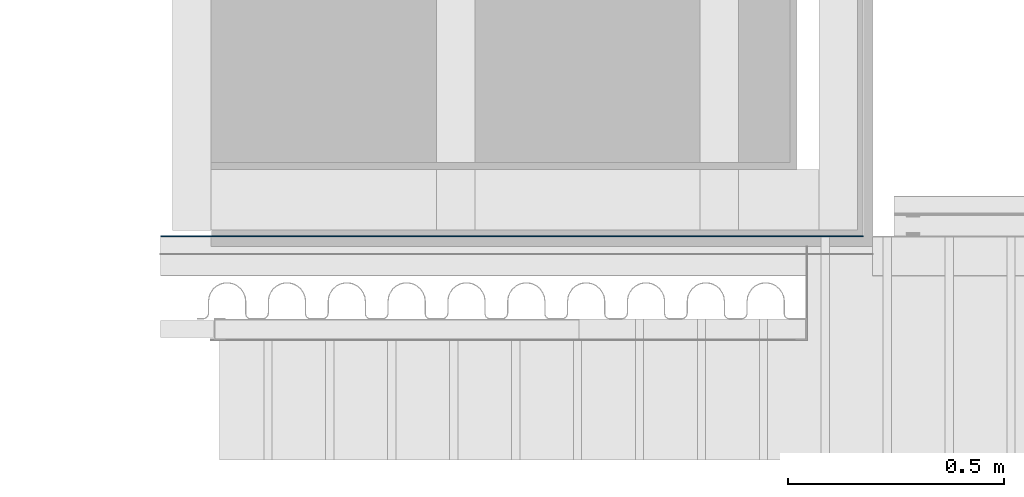
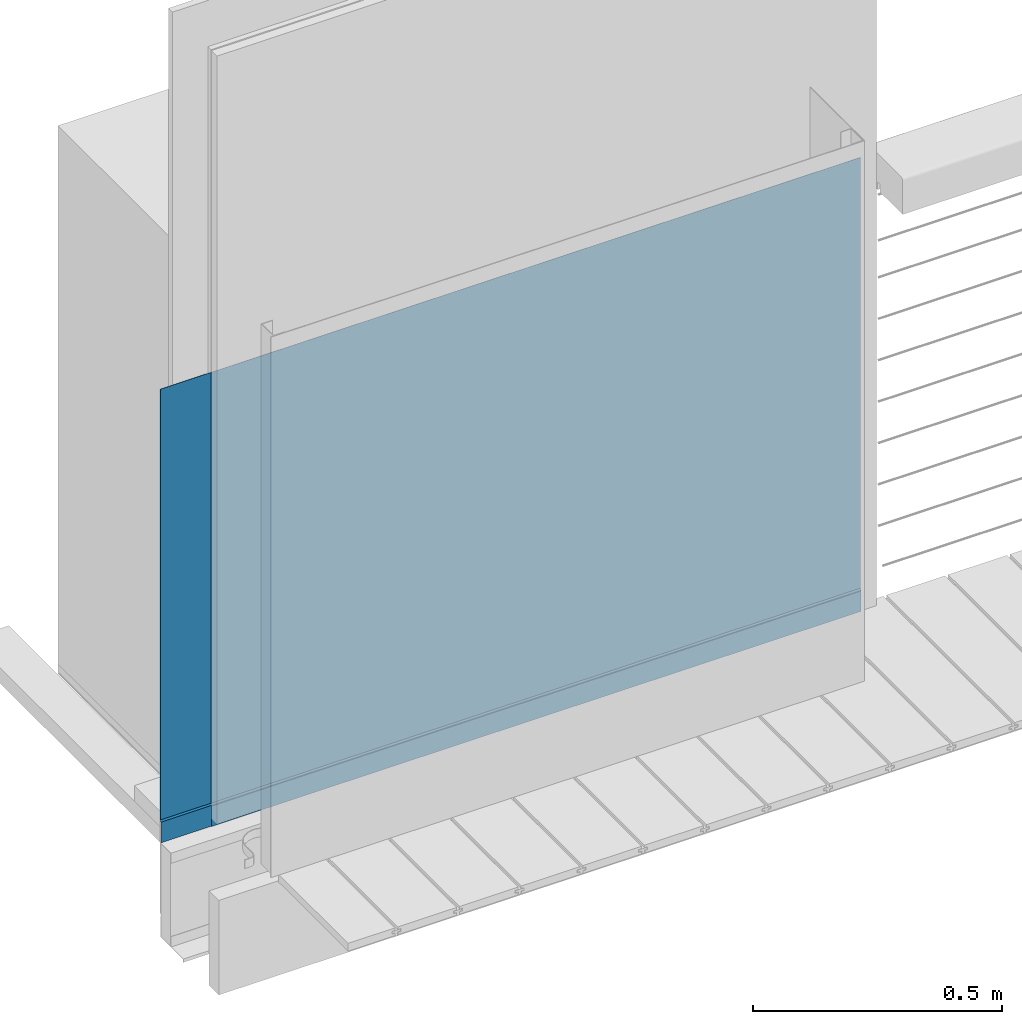
# One storey, part 10 of 33: 2 walls.
"""IFC4 building model written with IfcOpenShell, lengths in feet."""

from ifc_helpers import new_model, entity, si_unit, converted_unit, derived_unit, direction, frame, origin, place, context, subcontext, project, spatial, material, type_object, element, save


model = new_model("IFC4")

# Units and contexts
model_context = context("Model", 3, precision=0.0001, world=origin(), true_north=direction((6.12303176911189e-17, 1.0)))
body_context = subcontext(model_context, "Body", "Model", "MODEL_VIEW")
ifc_project = project(units=[converted_unit("LENGTHUNIT", "FOOT", entity("IfcRatioMeasure", 0.3048), si_unit("LENGTHUNIT", "METRE"), dimensions=[1, 0, 0, 0, 0, 0, 0]), converted_unit("AREAUNIT", "SQUARE FOOT", entity("IfcRatioMeasure", 0.09290304), si_unit("AREAUNIT", "SQUARE_METRE"), dimensions=[2, 0, 0, 0, 0, 0, 0]), converted_unit("VOLUMEUNIT", "CUBIC FOOT", entity("IfcRatioMeasure", 0.028316846592), si_unit("VOLUMEUNIT", "CUBIC_METRE"), dimensions=[3, 0, 0, 0, 0, 0, 0]), converted_unit("PLANEANGLEUNIT", "DEGREE", entity("IfcRatioMeasure", 0.0174532925199433), si_unit("PLANEANGLEUNIT", "RADIAN"), dimensions=[0, 0, 0, 0, 0, 0, 0]), si_unit("MASSUNIT", "GRAM", prefix="KILO"), derived_unit("MASSDENSITYUNIT", [(si_unit("MASSUNIT", "GRAM", prefix="KILO"), 1), (si_unit("LENGTHUNIT", "METRE"), -3)]), derived_unit("MOMENTOFINERTIAUNIT", [(si_unit("LENGTHUNIT", "METRE"), 4)]), si_unit("TIMEUNIT", "SECOND"), si_unit("FREQUENCYUNIT", "HERTZ"), si_unit("THERMODYNAMICTEMPERATUREUNIT", "DEGREE_CELSIUS"), derived_unit("THERMALTRANSMITTANCEUNIT", [(si_unit("MASSUNIT", "GRAM", prefix="KILO"), 1), (si_unit("THERMODYNAMICTEMPERATUREUNIT", "KELVIN"), -1), (si_unit("TIMEUNIT", "SECOND"), -3)]), derived_unit("VOLUMETRICFLOWRATEUNIT", [(si_unit("LENGTHUNIT", "METRE"), 3), (si_unit("TIMEUNIT", "SECOND"), -1)]), si_unit("ELECTRICCURRENTUNIT", "AMPERE"), si_unit("ELECTRICVOLTAGEUNIT", "VOLT"), si_unit("POWERUNIT", "WATT"), si_unit("FORCEUNIT", "NEWTON"), si_unit("ILLUMINANCEUNIT", "LUX"), si_unit("LUMINOUSFLUXUNIT", "LUMEN"), si_unit("LUMINOUSINTENSITYUNIT", "CANDELA"), derived_unit("USERDEFINED", [(si_unit("MASSUNIT", "GRAM", prefix="KILO"), -1), (si_unit("LENGTHUNIT", "METRE"), -2), (si_unit("TIMEUNIT", "SECOND"), 3), (si_unit("LUMINOUSFLUXUNIT", "LUMEN"), 1)]), derived_unit("LINEARVELOCITYUNIT", [(si_unit("LENGTHUNIT", "METRE"), 1), (si_unit("TIMEUNIT", "SECOND"), -1)]), si_unit("PRESSUREUNIT", "PASCAL"), derived_unit("USERDEFINED", [(si_unit("LENGTHUNIT", "METRE"), -2), (si_unit("MASSUNIT", "GRAM", prefix="KILO"), 1), (si_unit("TIMEUNIT", "SECOND"), -2)]), derived_unit("LINEARFORCEUNIT", [(si_unit("MASSUNIT", "GRAM", prefix="KILO"), 1), (si_unit("LENGTHUNIT", "METRE"), 1), (si_unit("TIMEUNIT", "SECOND"), -2), (si_unit("LENGTHUNIT", "METRE"), -1)]), derived_unit("PLANARFORCEUNIT", [(si_unit("MASSUNIT", "GRAM", prefix="KILO"), 1), (si_unit("LENGTHUNIT", "METRE"), 1), (si_unit("TIMEUNIT", "SECOND"), -2), (si_unit("LENGTHUNIT", "METRE"), -2)])], contexts=[model_context])

# Site, building, storey
site_placement = place(None, origin())
site = spatial("IfcSite", under=ifc_project, at=site_placement, CompositionType="ELEMENT")
building_placement = place(site_placement, origin())
building = spatial("IfcBuilding", under=site, at=building_placement, CompositionType="ELEMENT")
storey_placement = place(building_placement, frame((0.0, 0.0, 10.0)))
storey = spatial("IfcBuildingStorey", under=building, at=storey_placement, Name="2ND FLOOR", CompositionType="ELEMENT", Elevation=10.0000000000002)

# Walls
ifc_material = material(Name="BUILDING WRAP", Category="Materials")
wall_type_1 = type_object("IfcWallType", Name="building wrap:building wrap", PredefinedType="NOTDEFINED", material=ifc_material)
wall_1_placement = place(storey_placement, frame((1487.33128448684, 4.73909958454184, 0.681534345658772)))
cartesian_point_1 = entity("IfcCartesianPoint", [0.0, 0.0084646110221378, 0.178743324559218])
vertex_point_1 = entity("IfcVertexPoint", cartesian_point_1)
cartesian_point_2 = entity("IfcCartesianPoint", [0.0, 0.0084646110221378, 3.64995626492467])
vertex_point_2 = entity("IfcVertexPoint", cartesian_point_2)
ifc_direction_1 = entity("IfcDirection", [0.0, 0.0, 1.0])
edge_curve_1 = entity("IfcEdgeCurve", vertex_point_1, vertex_point_2, entity("IfcTrimmedCurve", entity("IfcLine", cartesian_point_1, entity("IfcVector", ifc_direction_1, 1.0)), [cartesian_point_1], [cartesian_point_2], True, "CARTESIAN"), True)
cartesian_point_3 = entity("IfcCartesianPoint", [0.0, 0.0110687776888048, 3.64995626492467])
vertex_point_3 = entity("IfcVertexPoint", cartesian_point_3)
ifc_direction_2 = entity("IfcDirection", [0.0, 1.0, 0.0])
edge_curve_2 = entity("IfcEdgeCurve", vertex_point_2, vertex_point_3, entity("IfcTrimmedCurve", entity("IfcLine", cartesian_point_2, entity("IfcVector", ifc_direction_2, 1.0)), [cartesian_point_2], [cartesian_point_3], True, "CARTESIAN"), True)
cartesian_point_4 = entity("IfcCartesianPoint", [0.0, 0.0110687776888048, 0.178045540203929])
vertex_point_4 = entity("IfcVertexPoint", cartesian_point_4)
ifc_direction_3 = entity("IfcDirection", [0.0, 0.0, -1.0])
edge_curve_3 = entity("IfcEdgeCurve", vertex_point_3, vertex_point_4, entity("IfcTrimmedCurve", entity("IfcLine", cartesian_point_3, entity("IfcVector", ifc_direction_3, 1.0)), [cartesian_point_3], [cartesian_point_4], True, "CARTESIAN"), True)
cartesian_point_5 = entity("IfcCartesianPoint", [0.0, 0.00260416666666696, 0.163384403847276])
vertex_point_5 = entity("IfcVertexPoint", cartesian_point_5)
edge_curve_4 = entity("IfcEdgeCurve", vertex_point_4, vertex_point_5, entity("IfcTrimmedCurve", entity("IfcLine", cartesian_point_4, entity("IfcVector", entity("IfcDirection", [0.0, -0.499999999999942, -0.866025403784472]), 1.0)), [cartesian_point_4], [cartesian_point_5], True, "CARTESIAN"), True)
cartesian_point_6 = entity("IfcCartesianPoint", [0.0, 0.00260416666666696, 0.0])
vertex_point_6 = entity("IfcVertexPoint", cartesian_point_6)
edge_curve_5 = entity("IfcEdgeCurve", vertex_point_5, vertex_point_6, entity("IfcTrimmedCurve", entity("IfcLine", cartesian_point_5, entity("IfcVector", ifc_direction_3, 1.0)), [cartesian_point_5], [cartesian_point_6], True, "CARTESIAN"), True)
cartesian_point_7 = entity("IfcCartesianPoint", [0.0, 0.0, 0.0])
vertex_point_7 = entity("IfcVertexPoint", cartesian_point_7)
ifc_direction_4 = entity("IfcDirection", [0.0, -1.0, 0.0])
edge_curve_6 = entity("IfcEdgeCurve", vertex_point_6, vertex_point_7, entity("IfcTrimmedCurve", entity("IfcLine", cartesian_point_6, entity("IfcVector", ifc_direction_4, 1.0)), [cartesian_point_6], [cartesian_point_7], True, "CARTESIAN"), True)
cartesian_point_8 = entity("IfcCartesianPoint", [0.0, 0.0, 0.164082188202567])
vertex_point_8 = entity("IfcVertexPoint", cartesian_point_8)
edge_curve_7 = entity("IfcEdgeCurve", vertex_point_7, vertex_point_8, entity("IfcTrimmedCurve", entity("IfcLine", cartesian_point_7, entity("IfcVector", ifc_direction_1, 1.0)), [cartesian_point_7], [cartesian_point_8], True, "CARTESIAN"), True)
edge_curve_8 = entity("IfcEdgeCurve", vertex_point_8, vertex_point_1, entity("IfcTrimmedCurve", entity("IfcLine", cartesian_point_8, entity("IfcVector", entity("IfcDirection", [0.0, 0.499999999999988, 0.866025403784446]), 1.0)), [cartesian_point_8], [cartesian_point_1], True, "CARTESIAN"), True)
ifc_direction_5 = entity("IfcDirection", [-1.0, 0.0, 0.0])
cartesian_point_9 = entity("IfcCartesianPoint", [4.94738904492056, 0.0084646110221378, 0.178743324559218])
vertex_point_9 = entity("IfcVertexPoint", cartesian_point_9)
cartesian_point_10 = entity("IfcCartesianPoint", [4.94738904492056, 0.0, 0.164082188202567])
vertex_point_10 = entity("IfcVertexPoint", cartesian_point_10)
edge_curve_9 = entity("IfcEdgeCurve", vertex_point_9, vertex_point_10, entity("IfcTrimmedCurve", entity("IfcLine", cartesian_point_9, entity("IfcVector", entity("IfcDirection", [0.0, -0.499999999999988, -0.866025403784446]), 1.0)), [cartesian_point_9], [cartesian_point_10], True, "CARTESIAN"), True)
cartesian_point_11 = entity("IfcCartesianPoint", [4.94738904492056, 0.0, 0.0])
vertex_point_11 = entity("IfcVertexPoint", cartesian_point_11)
edge_curve_10 = entity("IfcEdgeCurve", vertex_point_10, vertex_point_11, entity("IfcTrimmedCurve", entity("IfcLine", cartesian_point_10, entity("IfcVector", ifc_direction_3, 1.0)), [cartesian_point_10], [cartesian_point_11], True, "CARTESIAN"), True)
cartesian_point_12 = entity("IfcCartesianPoint", [4.94738904492056, 0.00260416666666696, 0.0])
vertex_point_12 = entity("IfcVertexPoint", cartesian_point_12)
edge_curve_11 = entity("IfcEdgeCurve", vertex_point_11, vertex_point_12, entity("IfcTrimmedCurve", entity("IfcLine", cartesian_point_11, entity("IfcVector", ifc_direction_2, 1.0)), [cartesian_point_11], [cartesian_point_12], True, "CARTESIAN"), True)
cartesian_point_13 = entity("IfcCartesianPoint", [4.94738904492056, 0.00260416666666696, 0.163384403847276])
vertex_point_13 = entity("IfcVertexPoint", cartesian_point_13)
edge_curve_12 = entity("IfcEdgeCurve", vertex_point_12, vertex_point_13, entity("IfcTrimmedCurve", entity("IfcLine", cartesian_point_12, entity("IfcVector", ifc_direction_1, 1.0)), [cartesian_point_12], [cartesian_point_13], True, "CARTESIAN"), True)
cartesian_point_14 = entity("IfcCartesianPoint", [4.94738904492056, 0.0110687776888048, 0.178045540203929])
vertex_point_14 = entity("IfcVertexPoint", cartesian_point_14)
edge_curve_13 = entity("IfcEdgeCurve", vertex_point_13, vertex_point_14, entity("IfcTrimmedCurve", entity("IfcLine", cartesian_point_13, entity("IfcVector", entity("IfcDirection", [0.0, 0.499999999999942, 0.866025403784472]), 1.0)), [cartesian_point_13], [cartesian_point_14], True, "CARTESIAN"), True)
cartesian_point_15 = entity("IfcCartesianPoint", [4.94738904492056, 0.0110687776888048, 3.64995626492467])
vertex_point_15 = entity("IfcVertexPoint", cartesian_point_15)
edge_curve_14 = entity("IfcEdgeCurve", vertex_point_14, vertex_point_15, entity("IfcTrimmedCurve", entity("IfcLine", cartesian_point_14, entity("IfcVector", ifc_direction_1, 1.0)), [cartesian_point_14], [cartesian_point_15], True, "CARTESIAN"), True)
cartesian_point_16 = entity("IfcCartesianPoint", [4.94738904492056, 0.0084646110221378, 3.64995626492467])
vertex_point_16 = entity("IfcVertexPoint", cartesian_point_16)
edge_curve_15 = entity("IfcEdgeCurve", vertex_point_15, vertex_point_16, entity("IfcTrimmedCurve", entity("IfcLine", cartesian_point_15, entity("IfcVector", ifc_direction_4, 1.0)), [cartesian_point_15], [cartesian_point_16], True, "CARTESIAN"), True)
edge_curve_16 = entity("IfcEdgeCurve", vertex_point_16, vertex_point_9, entity("IfcTrimmedCurve", entity("IfcLine", cartesian_point_16, entity("IfcVector", ifc_direction_3, 1.0)), [cartesian_point_16], [cartesian_point_9], True, "CARTESIAN"), True)
ifc_direction_6 = entity("IfcDirection", [1.0, 0.0, 0.0])
edge_curve_17 = entity("IfcEdgeCurve", vertex_point_1, vertex_point_9, entity("IfcTrimmedCurve", entity("IfcLine", cartesian_point_1, entity("IfcVector", ifc_direction_6, 1.0)), [cartesian_point_1], [cartesian_point_9], True, "CARTESIAN"), True)
edge_curve_18 = entity("IfcEdgeCurve", vertex_point_16, vertex_point_2, entity("IfcTrimmedCurve", entity("IfcLine", cartesian_point_2, entity("IfcVector", ifc_direction_5, 1.0)), [cartesian_point_16], [cartesian_point_2], True, "CARTESIAN"), True)
edge_curve_19 = entity("IfcEdgeCurve", vertex_point_15, vertex_point_3, entity("IfcTrimmedCurve", entity("IfcLine", cartesian_point_3, entity("IfcVector", ifc_direction_5, 1.0)), [cartesian_point_15], [cartesian_point_3], True, "CARTESIAN"), True)
edge_curve_20 = entity("IfcEdgeCurve", vertex_point_14, vertex_point_4, entity("IfcTrimmedCurve", entity("IfcLine", cartesian_point_4, entity("IfcVector", ifc_direction_5, 1.0)), [cartesian_point_14], [cartesian_point_4], True, "CARTESIAN"), True)
edge_curve_21 = entity("IfcEdgeCurve", vertex_point_13, vertex_point_5, entity("IfcTrimmedCurve", entity("IfcLine", cartesian_point_5, entity("IfcVector", ifc_direction_5, 1.0)), [cartesian_point_13], [cartesian_point_5], True, "CARTESIAN"), True)
edge_curve_22 = entity("IfcEdgeCurve", vertex_point_12, vertex_point_6, entity("IfcTrimmedCurve", entity("IfcLine", cartesian_point_6, entity("IfcVector", ifc_direction_5, 1.0)), [cartesian_point_12], [cartesian_point_6], True, "CARTESIAN"), True)
edge_curve_23 = entity("IfcEdgeCurve", vertex_point_11, vertex_point_7, entity("IfcTrimmedCurve", entity("IfcLine", cartesian_point_7, entity("IfcVector", ifc_direction_5, 1.0)), [cartesian_point_11], [cartesian_point_7], True, "CARTESIAN"), True)
edge_curve_24 = entity("IfcEdgeCurve", vertex_point_10, vertex_point_8, entity("IfcTrimmedCurve", entity("IfcLine", cartesian_point_8, entity("IfcVector", ifc_direction_5, 1.0)), [cartesian_point_10], [cartesian_point_8], True, "CARTESIAN"), True)
element("IfcWall", 1, at=wall_1_placement, inside=storey, type_object=wall_type_1, material=ifc_material, Name="building wrap:building wrap", ObjectType="building wrap:building wrap", PredefinedType="NOTDEFINED", context=body_context, shape_type="AdvancedBrep", body=[
    entity("IfcAdvancedBrep", entity("IfcClosedShell", [entity("IfcAdvancedFace", [entity("IfcFaceOuterBound", entity("IfcEdgeLoop", [entity("IfcOrientedEdge", None, None, edge_curve_1, True), entity("IfcOrientedEdge", None, None, edge_curve_2, True), entity("IfcOrientedEdge", None, None, edge_curve_3, True), entity("IfcOrientedEdge", None, None, edge_curve_4, True), entity("IfcOrientedEdge", None, None, edge_curve_5, True), entity("IfcOrientedEdge", None, None, edge_curve_6, True), entity("IfcOrientedEdge", None, None, edge_curve_7, True), entity("IfcOrientedEdge", None, None, edge_curve_8, True)]), True)], entity("IfcPlane", entity("IfcAxis2Placement3D", entity("IfcCartesianPoint", [0.0, 0.0084646110221378, 6.24554898767439]), ifc_direction_5, ifc_direction_1)), True), entity("IfcAdvancedFace", [entity("IfcFaceOuterBound", entity("IfcEdgeLoop", [entity("IfcOrientedEdge", None, None, edge_curve_9, True), entity("IfcOrientedEdge", None, None, edge_curve_10, True), entity("IfcOrientedEdge", None, None, edge_curve_11, True), entity("IfcOrientedEdge", None, None, edge_curve_12, True), entity("IfcOrientedEdge", None, None, edge_curve_13, True), entity("IfcOrientedEdge", None, None, edge_curve_14, True), entity("IfcOrientedEdge", None, None, edge_curve_15, True), entity("IfcOrientedEdge", None, None, edge_curve_16, True)]), True)], entity("IfcPlane", entity("IfcAxis2Placement3D", entity("IfcCartesianPoint", [4.94738904492056, 0.0084646110221378, 6.24554898767439]), ifc_direction_6, ifc_direction_3)), True), entity("IfcAdvancedFace", [entity("IfcFaceOuterBound", entity("IfcEdgeLoop", [entity("IfcOrientedEdge", None, None, edge_curve_1, False), entity("IfcOrientedEdge", None, None, edge_curve_17, True), entity("IfcOrientedEdge", None, None, edge_curve_16, False), entity("IfcOrientedEdge", None, None, edge_curve_18, True)]), True)], entity("IfcPlane", entity("IfcAxis2Placement3D", cartesian_point_1, ifc_direction_4, ifc_direction_6)), True), entity("IfcAdvancedFace", [entity("IfcFaceOuterBound", entity("IfcEdgeLoop", [entity("IfcOrientedEdge", None, None, edge_curve_2, False), entity("IfcOrientedEdge", None, None, edge_curve_18, False), entity("IfcOrientedEdge", None, None, edge_curve_15, False), entity("IfcOrientedEdge", None, None, edge_curve_19, True)]), True)], entity("IfcPlane", entity("IfcAxis2Placement3D", cartesian_point_2, ifc_direction_1, ifc_direction_6)), True), entity("IfcAdvancedFace", [entity("IfcFaceOuterBound", entity("IfcEdgeLoop", [entity("IfcOrientedEdge", None, None, edge_curve_3, False), entity("IfcOrientedEdge", None, None, edge_curve_19, False), entity("IfcOrientedEdge", None, None, edge_curve_14, False), entity("IfcOrientedEdge", None, None, edge_curve_20, True)]), True)], entity("IfcPlane", entity("IfcAxis2Placement3D", cartesian_point_3, ifc_direction_2, ifc_direction_6)), True), entity("IfcAdvancedFace", [entity("IfcFaceOuterBound", entity("IfcEdgeLoop", [entity("IfcOrientedEdge", None, None, edge_curve_4, False), entity("IfcOrientedEdge", None, None, edge_curve_20, False), entity("IfcOrientedEdge", None, None, edge_curve_13, False), entity("IfcOrientedEdge", None, None, edge_curve_21, True)]), True)], entity("IfcPlane", entity("IfcAxis2Placement3D", cartesian_point_4, entity("IfcDirection", [0.0, 0.866025403784472, -0.499999999999942]), ifc_direction_6)), True), entity("IfcAdvancedFace", [entity("IfcFaceOuterBound", entity("IfcEdgeLoop", [entity("IfcOrientedEdge", None, None, edge_curve_5, False), entity("IfcOrientedEdge", None, None, edge_curve_21, False), entity("IfcOrientedEdge", None, None, edge_curve_12, False), entity("IfcOrientedEdge", None, None, edge_curve_22, True)]), True)], entity("IfcPlane", entity("IfcAxis2Placement3D", cartesian_point_5, ifc_direction_2, ifc_direction_6)), True), entity("IfcAdvancedFace", [entity("IfcFaceOuterBound", entity("IfcEdgeLoop", [entity("IfcOrientedEdge", None, None, edge_curve_6, False), entity("IfcOrientedEdge", None, None, edge_curve_22, False), entity("IfcOrientedEdge", None, None, edge_curve_11, False), entity("IfcOrientedEdge", None, None, edge_curve_23, True)]), True)], entity("IfcPlane", entity("IfcAxis2Placement3D", cartesian_point_6, ifc_direction_3, ifc_direction_6)), True), entity("IfcAdvancedFace", [entity("IfcFaceOuterBound", entity("IfcEdgeLoop", [entity("IfcOrientedEdge", None, None, edge_curve_7, False), entity("IfcOrientedEdge", None, None, edge_curve_23, False), entity("IfcOrientedEdge", None, None, edge_curve_10, False), entity("IfcOrientedEdge", None, None, edge_curve_24, True)]), True)], entity("IfcPlane", entity("IfcAxis2Placement3D", cartesian_point_7, ifc_direction_4, ifc_direction_6)), True), entity("IfcAdvancedFace", [entity("IfcFaceOuterBound", entity("IfcEdgeLoop", [entity("IfcOrientedEdge", None, None, edge_curve_8, False), entity("IfcOrientedEdge", None, None, edge_curve_24, False), entity("IfcOrientedEdge", None, None, edge_curve_9, False), entity("IfcOrientedEdge", None, None, edge_curve_17, False)]), True)], entity("IfcPlane", entity("IfcAxis2Placement3D", cartesian_point_8, entity("IfcDirection", [0.0, -0.866025403784446, 0.499999999999988]), ifc_direction_6)), True)])),
])
wall_type_2 = type_object("IfcWallType", Name="Generic Models 676:Generic Models 1", PredefinedType="NOTDEFINED", material=ifc_material)
wall_2_placement = place(storey_placement, frame((1486.94745796881, 4.7398568531761, 0.684251668761348)))
cartesian_point_17 = entity("IfcCartesianPoint", [5.33128343753219, 0.010311509054536, 0.179124133240673])
vertex_point_17 = entity("IfcVertexPoint", cartesian_point_17)
cartesian_point_18 = entity("IfcCartesianPoint", [5.33128343753219, 0.010311509054536, 3.64733400573155])
vertex_point_18 = entity("IfcVertexPoint", cartesian_point_18)
ifc_direction_7 = entity("IfcDirection", [0.0, 0.0, 1.0])
edge_curve_25 = entity("IfcEdgeCurve", vertex_point_17, vertex_point_18, entity("IfcTrimmedCurve", entity("IfcLine", cartesian_point_17, entity("IfcVector", ifc_direction_7, 1.0)), [cartesian_point_17], [cartesian_point_18], True, "CARTESIAN"), True)
cartesian_point_19 = entity("IfcCartesianPoint", [5.33128343753219, 0.00770734238786908, 3.64733400573155])
vertex_point_19 = entity("IfcVertexPoint", cartesian_point_19)
ifc_direction_8 = entity("IfcDirection", [0.0, -1.0, 0.0])
edge_curve_26 = entity("IfcEdgeCurve", vertex_point_18, vertex_point_19, entity("IfcTrimmedCurve", entity("IfcLine", cartesian_point_18, entity("IfcVector", ifc_direction_8, 1.0)), [cartesian_point_18], [cartesian_point_19], True, "CARTESIAN"), True)
cartesian_point_20 = entity("IfcCartesianPoint", [5.33128343753219, 0.00770734238786908, 0.179821917595962])
vertex_point_20 = entity("IfcVertexPoint", cartesian_point_20)
ifc_direction_9 = entity("IfcDirection", [0.0, 0.0, -1.0])
edge_curve_27 = entity("IfcEdgeCurve", vertex_point_19, vertex_point_20, entity("IfcTrimmedCurve", entity("IfcLine", cartesian_point_19, entity("IfcVector", ifc_direction_9, 1.0)), [cartesian_point_19], [cartesian_point_20], True, "CARTESIAN"), True)
cartesian_point_21 = entity("IfcCartesianPoint", [5.33128343753219, 0.0, 0.166472408988843])
vertex_point_21 = entity("IfcVertexPoint", cartesian_point_21)
edge_curve_28 = entity("IfcEdgeCurve", vertex_point_20, vertex_point_21, entity("IfcTrimmedCurve", entity("IfcLine", cartesian_point_20, entity("IfcVector", entity("IfcDirection", [0.0, -0.499999999999987, -0.866025403784446]), 1.0)), [cartesian_point_20], [cartesian_point_21], True, "CARTESIAN"), True)
cartesian_point_22 = entity("IfcCartesianPoint", [5.33128343753219, 0.0, 0.0])
vertex_point_22 = entity("IfcVertexPoint", cartesian_point_22)
edge_curve_29 = entity("IfcEdgeCurve", vertex_point_21, vertex_point_22, entity("IfcTrimmedCurve", entity("IfcLine", cartesian_point_21, entity("IfcVector", ifc_direction_9, 1.0)), [cartesian_point_21], [cartesian_point_22], True, "CARTESIAN"), True)
cartesian_point_23 = entity("IfcCartesianPoint", [5.33128343753219, 0.00260416666666696, 0.0])
vertex_point_23 = entity("IfcVertexPoint", cartesian_point_23)
ifc_direction_10 = entity("IfcDirection", [0.0, 1.0, 0.0])
edge_curve_30 = entity("IfcEdgeCurve", vertex_point_22, vertex_point_23, entity("IfcTrimmedCurve", entity("IfcLine", cartesian_point_22, entity("IfcVector", ifc_direction_10, 1.0)), [cartesian_point_22], [cartesian_point_23], True, "CARTESIAN"), True)
cartesian_point_24 = entity("IfcCartesianPoint", [5.33128343753219, 0.00260416666666696, 0.165774624633555])
vertex_point_24 = entity("IfcVertexPoint", cartesian_point_24)
edge_curve_31 = entity("IfcEdgeCurve", vertex_point_23, vertex_point_24, entity("IfcTrimmedCurve", entity("IfcLine", cartesian_point_23, entity("IfcVector", ifc_direction_7, 1.0)), [cartesian_point_23], [cartesian_point_24], True, "CARTESIAN"), True)
edge_curve_32 = entity("IfcEdgeCurve", vertex_point_24, vertex_point_17, entity("IfcTrimmedCurve", entity("IfcLine", cartesian_point_24, entity("IfcVector", entity("IfcDirection", [0.0, 0.499999999999944, 0.866025403784471]), 1.0)), [cartesian_point_24], [cartesian_point_17], True, "CARTESIAN"), True)
ifc_direction_11 = entity("IfcDirection", [1.0, 0.0, 0.0])
cartesian_point_25 = entity("IfcCartesianPoint", [0.0, 0.010311509054624, 0.179124133240682])
vertex_point_25 = entity("IfcVertexPoint", cartesian_point_25)
cartesian_point_26 = entity("IfcCartesianPoint", [0.0, 0.00260416666675578, 0.165774624633563])
vertex_point_26 = entity("IfcVertexPoint", cartesian_point_26)
edge_curve_33 = entity("IfcEdgeCurve", vertex_point_25, vertex_point_26, entity("IfcTrimmedCurve", entity("IfcLine", cartesian_point_25, entity("IfcVector", entity("IfcDirection", [0.0, -0.499999999999944, -0.866025403784471]), 1.0)), [cartesian_point_25], [cartesian_point_26], True, "CARTESIAN"), True)
cartesian_point_27 = entity("IfcCartesianPoint", [0.0, 0.00260416666675489, 0.0])
vertex_point_27 = entity("IfcVertexPoint", cartesian_point_27)
edge_curve_34 = entity("IfcEdgeCurve", vertex_point_26, vertex_point_27, entity("IfcTrimmedCurve", entity("IfcLine", cartesian_point_26, entity("IfcVector", ifc_direction_9, 1.0)), [cartesian_point_26], [cartesian_point_27], True, "CARTESIAN"), True)
cartesian_point_28 = entity("IfcCartesianPoint", [0.0, 0.0, 0.0])
vertex_point_28 = entity("IfcVertexPoint", cartesian_point_28)
edge_curve_35 = entity("IfcEdgeCurve", vertex_point_27, vertex_point_28, entity("IfcTrimmedCurve", entity("IfcLine", cartesian_point_27, entity("IfcVector", ifc_direction_8, 1.0)), [cartesian_point_27], [cartesian_point_28], True, "CARTESIAN"), True)
cartesian_point_29 = entity("IfcCartesianPoint", [0.0, 0.0, 0.166472408988852])
vertex_point_29 = entity("IfcVertexPoint", cartesian_point_29)
edge_curve_36 = entity("IfcEdgeCurve", vertex_point_28, vertex_point_29, entity("IfcTrimmedCurve", entity("IfcLine", cartesian_point_28, entity("IfcVector", ifc_direction_7, 1.0)), [cartesian_point_28], [cartesian_point_29], True, "CARTESIAN"), True)
cartesian_point_30 = entity("IfcCartesianPoint", [0.0, 0.00770734238795701, 0.179821917595971])
vertex_point_30 = entity("IfcVertexPoint", cartesian_point_30)
edge_curve_37 = entity("IfcEdgeCurve", vertex_point_29, vertex_point_30, entity("IfcTrimmedCurve", entity("IfcLine", cartesian_point_29, entity("IfcVector", entity("IfcDirection", [0.0, 0.499999999999987, 0.866025403784446]), 1.0)), [cartesian_point_29], [cartesian_point_30], True, "CARTESIAN"), True)
cartesian_point_31 = entity("IfcCartesianPoint", [0.0, 0.00770734238795701, 3.64733400573156])
vertex_point_31 = entity("IfcVertexPoint", cartesian_point_31)
edge_curve_38 = entity("IfcEdgeCurve", vertex_point_30, vertex_point_31, entity("IfcTrimmedCurve", entity("IfcLine", cartesian_point_30, entity("IfcVector", ifc_direction_7, 1.0)), [cartesian_point_30], [cartesian_point_31], True, "CARTESIAN"), True)
cartesian_point_32 = entity("IfcCartesianPoint", [0.0, 0.010311509054624, 3.64733400573156])
vertex_point_32 = entity("IfcVertexPoint", cartesian_point_32)
edge_curve_39 = entity("IfcEdgeCurve", vertex_point_31, vertex_point_32, entity("IfcTrimmedCurve", entity("IfcLine", cartesian_point_31, entity("IfcVector", ifc_direction_10, 1.0)), [cartesian_point_31], [cartesian_point_32], True, "CARTESIAN"), True)
edge_curve_40 = entity("IfcEdgeCurve", vertex_point_32, vertex_point_25, entity("IfcTrimmedCurve", entity("IfcLine", cartesian_point_32, entity("IfcVector", ifc_direction_9, 1.0)), [cartesian_point_32], [cartesian_point_25], True, "CARTESIAN"), True)
ifc_direction_12 = entity("IfcDirection", [-1.0, 0.0, 0.0])
edge_curve_41 = entity("IfcEdgeCurve", vertex_point_25, vertex_point_17, entity("IfcTrimmedCurve", entity("IfcLine", cartesian_point_25, entity("IfcVector", ifc_direction_11, 1.0)), [cartesian_point_25], [cartesian_point_17], True, "CARTESIAN"), True)
edge_curve_42 = entity("IfcEdgeCurve", vertex_point_24, vertex_point_26, entity("IfcTrimmedCurve", entity("IfcLine", cartesian_point_26, entity("IfcVector", ifc_direction_12, 1.0)), [cartesian_point_24], [cartesian_point_26], True, "CARTESIAN"), True)
edge_curve_43 = entity("IfcEdgeCurve", vertex_point_23, vertex_point_27, entity("IfcTrimmedCurve", entity("IfcLine", cartesian_point_27, entity("IfcVector", ifc_direction_12, 1.0)), [cartesian_point_23], [cartesian_point_27], True, "CARTESIAN"), True)
edge_curve_44 = entity("IfcEdgeCurve", vertex_point_22, vertex_point_28, entity("IfcTrimmedCurve", entity("IfcLine", cartesian_point_28, entity("IfcVector", ifc_direction_12, 1.0)), [cartesian_point_22], [cartesian_point_28], True, "CARTESIAN"), True)
edge_curve_45 = entity("IfcEdgeCurve", vertex_point_31, vertex_point_19, entity("IfcTrimmedCurve", entity("IfcLine", cartesian_point_31, entity("IfcVector", ifc_direction_11, 1.0)), [cartesian_point_31], [cartesian_point_19], True, "CARTESIAN"), True)
edge_curve_46 = entity("IfcEdgeCurve", vertex_point_18, vertex_point_32, entity("IfcTrimmedCurve", entity("IfcLine", cartesian_point_32, entity("IfcVector", ifc_direction_12, 1.0)), [cartesian_point_18], [cartesian_point_32], True, "CARTESIAN"), True)
edge_curve_47 = entity("IfcEdgeCurve", vertex_point_21, vertex_point_29, entity("IfcTrimmedCurve", entity("IfcLine", cartesian_point_29, entity("IfcVector", ifc_direction_12, 1.0)), [cartesian_point_21], [cartesian_point_29], True, "CARTESIAN"), True)
edge_curve_48 = entity("IfcEdgeCurve", vertex_point_20, vertex_point_30, entity("IfcTrimmedCurve", entity("IfcLine", cartesian_point_30, entity("IfcVector", ifc_direction_12, 1.0)), [cartesian_point_20], [cartesian_point_30], True, "CARTESIAN"), True)
element("IfcWall", 2, at=wall_2_placement, inside=storey, type_object=wall_type_2, material=ifc_material, Name="Generic Models 676:Generic Models 1", ObjectType="Generic Models 676:Generic Models 1", PredefinedType="NOTDEFINED", context=body_context, shape_type="AdvancedBrep", body=[
    entity("IfcAdvancedBrep", entity("IfcClosedShell", [entity("IfcAdvancedFace", [entity("IfcFaceOuterBound", entity("IfcEdgeLoop", [entity("IfcOrientedEdge", None, None, edge_curve_25, True), entity("IfcOrientedEdge", None, None, edge_curve_26, True), entity("IfcOrientedEdge", None, None, edge_curve_27, True), entity("IfcOrientedEdge", None, None, edge_curve_28, True), entity("IfcOrientedEdge", None, None, edge_curve_29, True), entity("IfcOrientedEdge", None, None, edge_curve_30, True), entity("IfcOrientedEdge", None, None, edge_curve_31, True), entity("IfcOrientedEdge", None, None, edge_curve_32, True)]), True)], entity("IfcPlane", entity("IfcAxis2Placement3D", entity("IfcCartesianPoint", [5.33128343753219, -0.0571365003799729, 0.0623007540307139]), ifc_direction_11, entity("IfcDirection", [0.0, 0.499999999999987, 0.866025403784446]))), True), entity("IfcAdvancedFace", [entity("IfcFaceOuterBound", entity("IfcEdgeLoop", [entity("IfcOrientedEdge", None, None, edge_curve_33, True), entity("IfcOrientedEdge", None, None, edge_curve_34, True), entity("IfcOrientedEdge", None, None, edge_curve_35, True), entity("IfcOrientedEdge", None, None, edge_curve_36, True), entity("IfcOrientedEdge", None, None, edge_curve_37, True), entity("IfcOrientedEdge", None, None, edge_curve_38, True), entity("IfcOrientedEdge", None, None, edge_curve_39, True), entity("IfcOrientedEdge", None, None, edge_curve_40, True)]), True)], entity("IfcPlane", entity("IfcAxis2Placement3D", entity("IfcCartesianPoint", [0.0, -0.0571365003798849, 0.0623007540307228]), ifc_direction_12, entity("IfcDirection", [0.0, -0.499999999999987, -0.866025403784446]))), True), entity("IfcAdvancedFace", [entity("IfcFaceOuterBound", entity("IfcEdgeLoop", [entity("IfcOrientedEdge", None, None, edge_curve_33, False), entity("IfcOrientedEdge", None, None, edge_curve_41, True), entity("IfcOrientedEdge", None, None, edge_curve_32, False), entity("IfcOrientedEdge", None, None, edge_curve_42, True)]), True)], entity("IfcPlane", entity("IfcAxis2Placement3D", cartesian_point_25, entity("IfcDirection", [0.0, 0.866025403784446, -0.499999999999987]), ifc_direction_11)), True), entity("IfcAdvancedFace", [entity("IfcFaceOuterBound", entity("IfcEdgeLoop", [entity("IfcOrientedEdge", None, None, edge_curve_34, False), entity("IfcOrientedEdge", None, None, edge_curve_42, False), entity("IfcOrientedEdge", None, None, edge_curve_31, False), entity("IfcOrientedEdge", None, None, edge_curve_43, True)]), True)], entity("IfcPlane", entity("IfcAxis2Placement3D", cartesian_point_26, ifc_direction_10, ifc_direction_11)), True), entity("IfcAdvancedFace", [entity("IfcFaceOuterBound", entity("IfcEdgeLoop", [entity("IfcOrientedEdge", None, None, edge_curve_35, False), entity("IfcOrientedEdge", None, None, edge_curve_43, False), entity("IfcOrientedEdge", None, None, edge_curve_30, False), entity("IfcOrientedEdge", None, None, edge_curve_44, True)]), True)], entity("IfcPlane", entity("IfcAxis2Placement3D", cartesian_point_27, ifc_direction_9, ifc_direction_11)), True), entity("IfcAdvancedFace", [entity("IfcFaceOuterBound", entity("IfcEdgeLoop", [entity("IfcOrientedEdge", None, None, edge_curve_39, False), entity("IfcOrientedEdge", None, None, edge_curve_45, True), entity("IfcOrientedEdge", None, None, edge_curve_26, False), entity("IfcOrientedEdge", None, None, edge_curve_46, True)]), True)], entity("IfcPlane", entity("IfcAxis2Placement3D", cartesian_point_31, ifc_direction_7, ifc_direction_11)), True), entity("IfcAdvancedFace", [entity("IfcFaceOuterBound", entity("IfcEdgeLoop", [entity("IfcOrientedEdge", None, None, edge_curve_40, False), entity("IfcOrientedEdge", None, None, edge_curve_46, False), entity("IfcOrientedEdge", None, None, edge_curve_25, False), entity("IfcOrientedEdge", None, None, edge_curve_41, False)]), True)], entity("IfcPlane", entity("IfcAxis2Placement3D", cartesian_point_32, ifc_direction_10, ifc_direction_11)), True), entity("IfcAdvancedFace", [entity("IfcFaceOuterBound", entity("IfcEdgeLoop", [entity("IfcOrientedEdge", None, None, edge_curve_36, False), entity("IfcOrientedEdge", None, None, edge_curve_44, False), entity("IfcOrientedEdge", None, None, edge_curve_29, False), entity("IfcOrientedEdge", None, None, edge_curve_47, True)]), True)], entity("IfcPlane", entity("IfcAxis2Placement3D", cartesian_point_28, ifc_direction_8, ifc_direction_11)), True), entity("IfcAdvancedFace", [entity("IfcFaceOuterBound", entity("IfcEdgeLoop", [entity("IfcOrientedEdge", None, None, edge_curve_37, False), entity("IfcOrientedEdge", None, None, edge_curve_47, False), entity("IfcOrientedEdge", None, None, edge_curve_28, False), entity("IfcOrientedEdge", None, None, edge_curve_48, True)]), True)], entity("IfcPlane", entity("IfcAxis2Placement3D", cartesian_point_29, entity("IfcDirection", [0.0, -0.866025403784446, 0.499999999999987]), ifc_direction_11)), True), entity("IfcAdvancedFace", [entity("IfcFaceOuterBound", entity("IfcEdgeLoop", [entity("IfcOrientedEdge", None, None, edge_curve_38, False), entity("IfcOrientedEdge", None, None, edge_curve_48, False), entity("IfcOrientedEdge", None, None, edge_curve_27, False), entity("IfcOrientedEdge", None, None, edge_curve_45, False)]), True)], entity("IfcPlane", entity("IfcAxis2Placement3D", cartesian_point_30, ifc_direction_8, ifc_direction_11)), True)])),
])

save(model, "model.ifc")
